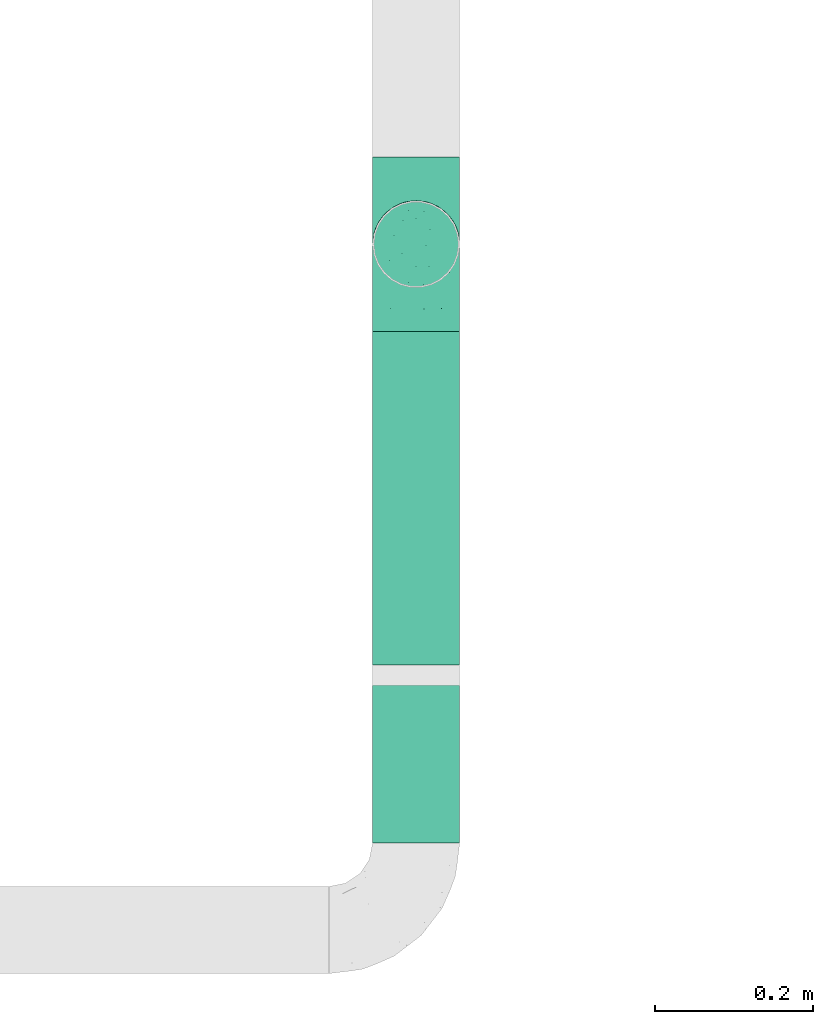
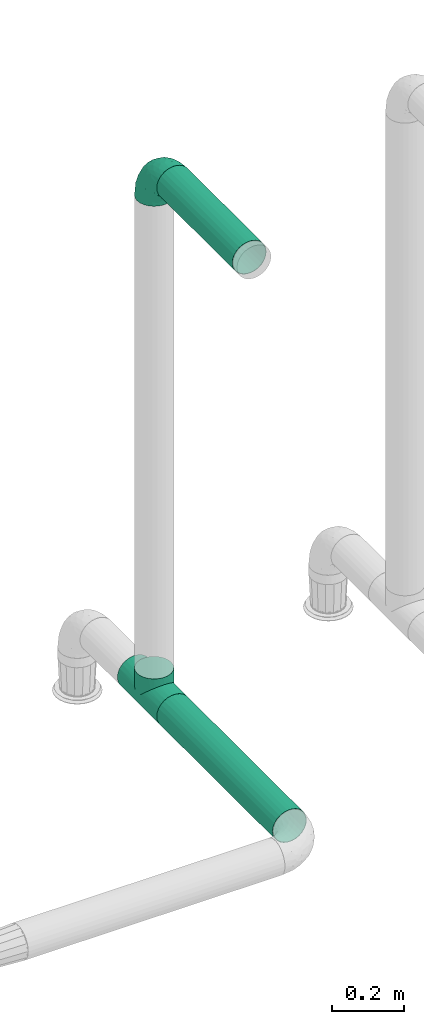
# One storey, part 9 of 103: 2 flow fittings, 2 flow segments.
"""IFC2X3 building model written with IfcOpenShell, lengths in millimetres."""

from ifc_helpers import new_model, entity, si_unit, converted_unit, derived_unit, direction, frame, origin_with_axes, origin_2d_with_axis, place, context, subcontext, project, spatial, hollow_circle, extrude, open_shell, surface_model, source, transform, mapped, material, layer, layer_set, layer_usage, type_object, element, save


model = new_model("IFC2X3")

# Units and contexts
model_context = context("Model", 3, precision=1e-05, world=origin_with_axes(), true_north=direction((0.0, 1.0)))
body_context = subcontext(model_context, "Body", "Model", "MODEL_VIEW")
ifc_project = project(units=[si_unit("AREAUNIT", "SQUARE_METRE"), si_unit("VOLUMEUNIT", "CUBIC_METRE", prefix="DECI"), si_unit("TIMEUNIT", "SECOND"), si_unit("THERMODYNAMICTEMPERATUREUNIT", "DEGREE_CELSIUS"), si_unit("PRESSUREUNIT", "PASCAL"), si_unit("MASSUNIT", "GRAM", prefix="KILO"), si_unit("LENGTHUNIT", "METRE", prefix="MILLI"), si_unit("POWERUNIT", "WATT"), si_unit("ELECTRICCURRENTUNIT", "AMPERE"), si_unit("ELECTRICVOLTAGEUNIT", "VOLT"), derived_unit("VOLUMETRICFLOWRATEUNIT", [(si_unit("VOLUMEUNIT", "CUBIC_METRE", prefix="DECI"), 1), (si_unit("TIMEUNIT", "SECOND"), -1)]), derived_unit("LINEARVELOCITYUNIT", [(si_unit("LENGTHUNIT", "METRE"), 1), (si_unit("TIMEUNIT", "SECOND"), -1)]), derived_unit("MASSDENSITYUNIT", [(si_unit("MASSUNIT", "GRAM", prefix="KILO"), 1), (si_unit("VOLUMEUNIT", "CUBIC_METRE"), -1)]), converted_unit("PLANEANGLEUNIT", "DEGREE", entity("IfcRatioMeasure", 0.01745), si_unit("PLANEANGLEUNIT", "RADIAN"), dimensions=[0, 0, 0, 0, 0, 0, 0])], contexts=[model_context])

# Site, building, storey
site_placement = place(None, origin_with_axes())
site = spatial("IfcSite", under=ifc_project, at=site_placement, CompositionType="ELEMENT")
building_placement = place(site_placement, origin_with_axes())
building = spatial("IfcBuilding", under=site, at=building_placement, Name="mc-building", CompositionType="ELEMENT")
storey_placement = place(building_placement, frame((0.0, 0.0, 5900.0), z_axis=(0.0, 0.0, 1.0), x_axis=(1.0, 0.0, 0.0)))
storey = spatial("IfcBuildingStorey", under=building, at=storey_placement, Name="3. Korrus", CompositionType="ELEMENT", Elevation=5900.0)

# Flow fitting
duct_fitting_type_1 = type_object("IfcDuctFittingType", PredefinedType="JUNCTION")
shared_shape_1 = source(origin_with_axes(), body_context, "Body", "SurfaceModel", [
    surface_model("IfcShellBasedSurfaceModel", [(0.0, -80.0, -55.0), (14.23505, -80.0, -53.12592), (-14.23505, -80.0, -53.12592), (-53.12592, -80.0, 14.23505), (-27.5, -80.0, -47.63139), (-47.63139, -80.0, -27.5), (-38.89087, -80.0, -38.89087), (55.0, -80.0, 0.0), (53.12592, -80.0, 14.23505), (38.89087, -80.0, -38.89087), (27.5, -80.0, -47.63139), (53.12592, -80.0, -14.23505), (47.63139, -80.0, -27.5), (-53.12592, -80.0, -14.23505), (-47.63139, -80.0, 27.5), (-38.89087, -80.0, 38.89087), (14.23505, -80.0, 53.12592), (-27.5, -80.0, 47.63139), (-14.23505, -80.0, 53.12592), (47.63139, -80.0, 27.5), (38.89087, -80.0, 38.89087), (27.5, -80.0, 47.63139), (0.0, -80.0, 55.0), (-55.0, -80.0, 0.0), (0.0, 0.0, 55.0), (-7.4066, -7.4066, 54.49901), (-14.74521, -14.74521, 52.98659), (-21.93978, -21.93978, 50.43457), (-28.89905, -28.89905, 46.79578), (-35.50357, -35.50357, 42.00591), (-41.58668, -41.58668, 35.99373), (-46.92319, -46.92319, 28.69171), (-51.19777, -51.19777, 20.0945), (-50.37866, -80.0, 20.86752), (-54.01174, -54.01174, 10.37938), (-55.0, -55.0, 0.0), (-54.06296, -80.0, 7.11752), (-54.01174, -54.01174, -10.37938), (-51.19777, -51.19777, -20.0945), (-54.06296, -80.0, -7.11752), (-46.92319, -46.92319, -28.69171), (-41.58668, -41.58668, -35.99373), (-50.37866, -80.0, -20.86752), (-35.50357, -35.50357, -42.00591), (-21.93978, -21.93978, -50.43457), (-14.74521, -14.74521, -52.98659), (-7.4066, -7.4066, -54.49901), (0.0, 0.0, -55.0), (-28.89905, -28.89905, -46.79578), (7.4066, -7.4066, -54.49901), (14.74521, -14.74521, -52.98659), (21.93978, -21.93978, -50.43457), (28.89905, -28.89905, -46.79578), (35.50357, -35.50357, -42.00591), (41.58668, -41.58668, -35.99373), (46.92319, -46.92319, -28.69171), (51.19777, -51.19777, -20.0945), (50.37866, -80.0, -20.86752), (54.01174, -54.01174, -10.37938), (55.0, -55.0, 0.0), (54.06296, -80.0, -7.11752), (54.01174, -54.01174, 10.37938), (51.19777, -51.19777, 20.0945), (54.06296, -80.0, 7.11752), (46.92319, -46.92319, 28.69171), (41.58668, -41.58668, 35.99373), (50.37866, -80.0, 20.86752), (35.50357, -35.50357, 42.00591), (21.93978, -21.93978, 50.43457), (14.74521, -14.74521, 52.98659), (7.4066, -7.4066, 54.49901), (28.89905, -28.89905, 46.79578), (-110.0, 0.0, -55.0), (-110.0, -14.23505, -53.12592), (-110.0, 14.23505, -53.12592), (-110.0, 53.12592, 14.23505), (-110.0, 27.5, -47.63139), (-110.0, 47.63139, -27.5), (-110.0, 38.89087, -38.89087), (-110.0, -55.0, 0.0), (-110.0, -53.12592, 14.23505), (-110.0, -38.89087, -38.89087), (-110.0, -27.5, -47.63139), (-110.0, -53.12592, -14.23505), (-110.0, -47.63139, -27.5), (-110.0, 53.12592, -14.23505), (-110.0, 47.63139, 27.5), (-110.0, 38.89087, 38.89087), (-110.0, -14.23505, 53.12592), (-110.0, 27.5, 47.63139), (-110.0, 14.23505, 53.12592), (-110.0, -47.63139, 27.5), (-110.0, -38.89087, 38.89087), (-110.0, -27.5, 47.63139), (-110.0, 0.0, 55.0), (-110.0, 55.0, 0.0), (110.0, 55.0, 0.0), (110.0, 0.0, -55.0), (110.0, 14.23505, -53.12592), (110.0, 27.5, -47.63139), (110.0, 38.89087, -38.89087), (110.0, 47.63139, -27.5), (110.0, -38.89087, -38.89087), (110.0, -53.12592, 14.23505), (110.0, -27.5, -47.63139), (110.0, -14.23505, -53.12592), (110.0, -47.63139, -27.5), (110.0, -53.12592, -14.23505), (110.0, -55.0, 0.0), (110.0, 53.12592, -14.23505), (110.0, 53.12592, 14.23505), (110.0, 47.63139, 27.5), (110.0, 38.89087, 38.89087), (110.0, 0.0, 55.0), (110.0, 27.5, 47.63139), (110.0, 14.23505, 53.12592), (110.0, -47.63139, 27.5), (110.0, -38.89087, 38.89087), (110.0, -27.5, 47.63139), (110.0, -14.23505, 53.12592)], [open_shell([[[0, 1, 2]], [[2, 3, 4]], [[5, 6, 3]], [[6, 4, 3]], [[2, 7, 8]], [[9, 7, 10]], [[1, 10, 7]], [[11, 7, 12]], [[9, 12, 7]], [[7, 2, 1]], [[5, 3, 13]], [[2, 14, 3]], [[2, 15, 14]], [[2, 16, 17]], [[17, 15, 2]], [[16, 18, 17]], [[2, 8, 19]], [[2, 19, 20]], [[2, 20, 21]], [[16, 2, 21]], [[16, 22, 18]], [[23, 13, 3]], [[24, 25, 22]], [[26, 27, 18]], [[25, 26, 18]], [[22, 25, 18]], [[17, 28, 29]], [[17, 18, 27]], [[17, 29, 15]], [[28, 17, 27]], [[30, 31, 14]], [[32, 3, 33]], [[32, 34, 3]], [[35, 36, 34]], [[31, 32, 14]], [[15, 30, 14]], [[34, 36, 3]], [[33, 14, 32]], [[36, 35, 23]], [[30, 15, 29]], [[37, 38, 13]], [[37, 13, 39]], [[40, 41, 5]], [[38, 5, 42]], [[38, 40, 5]], [[37, 39, 35]], [[35, 39, 23]], [[13, 38, 42]], [[41, 6, 5]], [[41, 43, 6]], [[44, 45, 2]], [[46, 47, 0]], [[45, 46, 2]], [[43, 48, 4]], [[44, 4, 48]], [[44, 2, 4]], [[46, 0, 2]], [[43, 4, 6]], [[47, 49, 0]], [[50, 51, 1]], [[49, 50, 1]], [[0, 49, 1]], [[10, 52, 53]], [[10, 1, 51]], [[10, 53, 9]], [[52, 10, 51]], [[54, 55, 12]], [[56, 11, 57]], [[56, 58, 11]], [[59, 60, 58]], [[55, 56, 12]], [[9, 54, 12]], [[58, 60, 11]], [[57, 12, 56]], [[60, 59, 7]], [[54, 9, 53]], [[61, 62, 8]], [[61, 8, 63]], [[64, 65, 19]], [[62, 19, 66]], [[62, 64, 19]], [[61, 63, 59]], [[7, 59, 63]], [[62, 66, 8]], [[65, 20, 19]], [[65, 67, 20]], [[68, 69, 16]], [[70, 24, 22]], [[69, 70, 16]], [[67, 71, 21]], [[68, 21, 71]], [[68, 16, 21]], [[70, 22, 16]], [[67, 21, 20]], [[72, 73, 74]], [[74, 75, 76]], [[77, 78, 75]], [[76, 75, 78]], [[74, 79, 80]], [[81, 79, 82]], [[73, 82, 79]], [[83, 79, 84]], [[81, 84, 79]], [[79, 74, 73]], [[77, 75, 85]], [[74, 86, 75]], [[74, 87, 86]], [[74, 88, 89]], [[89, 87, 74]], [[88, 90, 89]], [[74, 91, 92]], [[91, 74, 80]], [[92, 93, 74]], [[74, 93, 88]], [[88, 94, 90]], [[95, 85, 75]], [[96, 97, 98]], [[99, 96, 98]], [[96, 100, 101]], [[100, 96, 99]], [[102, 97, 103]], [[97, 102, 104]], [[104, 105, 97]], [[102, 103, 106]], [[106, 103, 107]], [[108, 107, 103]], [[109, 96, 101]], [[110, 111, 97]], [[97, 111, 112]], [[113, 97, 114]], [[97, 112, 114]], [[113, 114, 115]], [[116, 103, 97]], [[117, 116, 97]], [[118, 117, 97]], [[119, 118, 97]], [[119, 97, 113]], [[96, 110, 97]], [[24, 113, 115]], [[89, 115, 114]], [[94, 24, 90]], [[90, 24, 115]], [[115, 89, 90]], [[114, 87, 89]], [[86, 112, 111]], [[75, 111, 110]], [[95, 110, 96]], [[87, 112, 86]], [[86, 111, 75]], [[110, 95, 75]], [[112, 87, 114]], [[85, 96, 109]], [[77, 109, 101]], [[95, 96, 85]], [[85, 109, 77]], [[101, 78, 77]], [[101, 100, 78]], [[76, 100, 99]], [[74, 99, 98]], [[47, 98, 97]], [[76, 99, 74]], [[47, 72, 74]], [[98, 47, 74]], [[100, 76, 78]], [[47, 46, 72]], [[45, 44, 73]], [[46, 45, 73]], [[72, 46, 73]], [[82, 48, 43]], [[82, 73, 44]], [[82, 43, 81]], [[48, 82, 44]], [[41, 40, 84]], [[38, 37, 83]], [[40, 38, 84]], [[81, 41, 84]], [[37, 79, 83]], [[83, 84, 38]], [[79, 37, 35]], [[41, 81, 43]], [[49, 97, 105]], [[105, 104, 51]], [[53, 104, 102]], [[53, 52, 104]], [[49, 47, 97]], [[51, 50, 105]], [[52, 51, 104]], [[49, 105, 50]], [[54, 102, 106]], [[56, 106, 107]], [[58, 107, 108]], [[55, 54, 106]], [[58, 56, 107]], [[59, 58, 108]], [[55, 106, 56]], [[102, 54, 53]], [[34, 32, 80]], [[31, 30, 91]], [[32, 31, 91]], [[35, 34, 79]], [[80, 79, 34]], [[32, 91, 80]], [[30, 92, 91]], [[30, 29, 92]], [[27, 26, 88]], [[25, 24, 94]], [[26, 25, 88]], [[29, 28, 93]], [[27, 93, 28]], [[27, 88, 93]], [[25, 94, 88]], [[29, 93, 92]], [[61, 108, 103]], [[62, 103, 116]], [[65, 116, 117]], [[61, 59, 108]], [[64, 62, 116]], [[65, 64, 116]], [[61, 103, 62]], [[117, 67, 65]], [[71, 67, 118]], [[118, 67, 117]], [[68, 118, 119]], [[70, 119, 113]], [[68, 71, 118]], [[70, 69, 119]], [[24, 70, 113]], [[68, 119, 69]]])]),
])
flow_fitting_1_placement = place(storey_placement, frame((8385.80789, 4302.28735, 2345.0), z_axis=(-1.0, 0.0, 0.0), x_axis=(0.0, 1.0, 0.0)))
element("IfcFlowFitting", 1, at=flow_fitting_1_placement, inside=storey, type_object=duct_fitting_type_1, context=body_context, shape_type="MappedRepresentation", body=[
    mapped(shared_shape_1, transform((0.0, 0.0, 0.0), scale=1.0)),
])

# Flow segment
ifc_material = material(Name="FZ1")
ifc_layer = layer(ifc_material, 0.0)
ifc_layer_set = layer_set([ifc_layer], Name="FZ1")
ifc_layer_usage = layer_usage(ifc_layer_set, "AXIS1", "POSITIVE", 0.0)
duct_segment_type = type_object("IfcDuctSegmentType", Name="Safe", PredefinedType="RIGIDSEGMENT")
shared_shape_2 = source(origin_with_axes(), body_context, "Body", "SweptSolid", [
    extrude(hollow_circle(Radius=55.0, WallThickness=2.0, at=origin_2d_with_axis()), frame((0.0, 0.0, 0.0), z_axis=(1.0, 0.0, 0.0), x_axis=(0.0, 1.0, 0.0)), (0.0, 0.0, 1.0), 645.5),
])
flow_segment_1_placement = place(storey_placement, frame((8385.80789, 3546.80698, 2345.0), z_axis=(0.0, 0.0, 1.0), x_axis=(0.0, 1.0, 0.0)))
element("IfcFlowSegment", 2, at=flow_segment_1_placement, inside=storey, type_object=duct_segment_type, material=ifc_layer_usage, Name="Safe", context=body_context, shape_type="MappedRepresentation", body=[
    mapped(shared_shape_2, transform((0.0, 0.0, 0.0), scale=1.0)),
])

# Flow fitting
duct_fitting_type_2 = type_object("IfcDuctFittingType", Name="BU", PredefinedType="BEND")
shared_shape_3 = source(origin_with_axes(), body_context, "Body", "SurfaceModel", [
    surface_model("IfcShellBasedSurfaceModel", [(-110.0, 0.0, -55.0), (-110.0, -14.23505, -53.12592), (-110.0, 14.23505, -53.12592), (-110.0, 53.12592, 14.23505), (-110.0, 27.5, -47.63139), (-110.0, 38.89087, -38.89087), (-110.0, -55.0, 0.0), (-110.0, -53.12592, 14.23505), (-110.0, -38.89087, -38.89087), (-110.0, -27.5, -47.63139), (-110.0, -53.12592, -14.23505), (-110.0, -47.63139, -27.5), (-110.0, -14.23505, 53.12592), (-110.0, 14.23505, 53.12592), (-110.0, 27.5, 47.63139), (-110.0, -47.63139, 27.5), (-110.0, -38.89087, 38.89087), (-110.0, -27.5, 47.63139), (-110.0, 0.0, 55.0), (-110.0, 55.0, 0.0), (-110.0, 53.12592, -14.23505), (-110.0, 47.63139, -27.5), (-110.0, 47.63139, 27.5), (-110.0, 38.89087, 38.89087), (-14.23505, 110.0, -53.12592), (-55.0, 110.0, 0.0), (0.0, 110.0, -55.0), (-27.5, 110.0, -47.63139), (-38.89087, 110.0, -38.89087), (-47.63139, 110.0, -27.5), (38.89087, 110.0, -38.89087), (53.12592, 110.0, 14.23505), (27.5, 110.0, -47.63139), (14.23505, 110.0, -53.12592), (47.63139, 110.0, -27.5), (53.12592, 110.0, -14.23505), (55.0, 110.0, 0.0), (-53.12592, 110.0, -14.23505), (-53.12592, 110.0, 14.23505), (-47.63139, 110.0, 27.5), (-38.89087, 110.0, 38.89087), (-27.5, 110.0, 47.63139), (0.0, 110.0, 55.0), (-14.23505, 110.0, 53.12592), (38.89087, 110.0, 38.89087), (47.63139, 110.0, 27.5), (27.5, 110.0, 47.63139), (14.23505, 110.0, 53.12592), (-64.21732, 48.68956, 43.63444), (-76.6405, 38.18013, 45.55988), (-60.44912, 32.56953, 51.94617), (-76.00813, 5.38378, 55.0), (-90.15553, 11.94394, 54.09138), (-78.5998, 26.77405, 50.81338), (-70.18771, 18.55163, 54.03432), (-75.55424, 54.2118, 32.41257), (-93.27622, 45.77614, 33.48188), (-96.12334, 22.13664, 50.81337), (-21.00813, 45.34362, 55.0), (-18.36258, 70.48427, 54.04484), (-32.04182, 59.64019, 52.24446), (-63.88653, 74.77858, 17.99134), (-74.66383, 63.08407, 19.92123), (-63.60674, 66.07878, 29.97482), (-99.597, 52.72185, 18.52927), (-93.11138, 56.59448, 10.50359), (-98.21577, 57.34403, 0.0), (-53.42855, 92.60092, 21.04759), (-88.54852, 54.8376, 21.04759), (-11.86161, 90.23965, 54.10313), (-5.38378, 76.00813, 55.0), (-57.34403, 98.21577, 0.0), (-56.64619, 93.12774, 10.22088), (-45.34362, 21.00813, 55.0), (-44.60838, 44.60838, 52.13415), (-92.68484, 35.46673, 43.63443), (-22.25266, 95.40765, 50.81337), (-35.97783, 90.61597, 43.63443), (-43.70931, 69.58671, 44.47149), (-27.23711, 77.39884, 50.81337), (-57.2828, 79.3123, 24.9774), (-58.67786, 84.31125, 16.04456), (-82.93277, 60.36161, 12.91784), (-49.88337, 54.51816, 47.224), (-74.57753, 66.83759, 9.55742), (-45.35812, 94.97281, 33.48188), (-59.18663, 88.95241, 0.0), (-51.517, 78.6292, 33.48188), (-65.14788, 80.03077, 0.0), (-56.45322, 62.06476, 39.63545), (-88.95241, 59.18663, 0.0), (-71.10913, 71.10913, 0.0), (-80.03077, 65.14788, 0.0), (-94.9309, 45.36788, -33.48188), (-93.11358, 56.60141, -10.46614), (-99.64997, 52.79499, -18.30015), (-90.20425, 36.08686, -43.63443), (-79.99933, 46.56772, -37.92748), (-76.00813, 5.38378, -55.0), (-72.75364, 19.68651, -53.60527), (-45.34362, 21.00813, -55.0), (-21.91957, 65.12078, -53.85897), (-5.38378, 76.00813, -55.0), (-21.00813, 45.34362, -55.0), (-35.41876, 92.89265, -43.63443), (-91.10309, 11.02766, -54.21832), (-45.77614, 93.27622, -33.48188), (-90.50474, 23.21022, -50.81337), (-70.92854, 33.31794, -49.51754), (-78.52933, 63.35627, -11.73997), (-24.91508, 84.05606, -50.81337), (-88.78941, 54.74452, -21.04759), (-69.59921, 57.34866, -33.48187), (-73.36422, 62.46673, -22.94182), (-63.49062, 67.59111, -28.46929), (-56.59448, 93.11138, -10.50359), (-54.8376, 88.54852, -21.04759), (-54.10679, 75.85581, -32.31867), (-57.75956, 31.09612, -52.80882), (-52.72185, 99.597, -18.52927), (-12.62913, 89.46304, -53.99097), (-34.46825, 66.46123, -50.04329), (-43.9837, 43.9837, -52.42279), (-65.78527, 72.58348, -17.68796), (-70.34468, 43.65295, -44.21951), (-57.47001, 51.99467, -44.91465), (-60.72547, 82.29174, -12.88567), (-42.34915, 74.24548, -43.63444), (-57.25194, 63.5016, -38.08211), (-80.95344, 53.56991, -29.32027), (-52.32891, 4.55257, -54.0482), (32.52942, 47.13398, -30.48571), (14.88266, 20.92917, -33.7947), (14.95561, 36.05775, -42.26543), (30.24048, 70.09027, -41.7461), (19.3559, 65.35825, -48.00507), (-70.35075, -46.44478, -19.5952), (-47.13398, -32.52942, -30.48571), (-28.49299, -30.5778, -16.4009), (-4.55257, 52.32891, -54.0482), (-22.4954, 22.4954, -53.25347), (-75.47368, -11.22546, -52.60718), (-81.32209, -51.5606, -9.98467), (-80.81763, -41.84862, -32.14655), (-70.09027, -30.24048, -41.7461), (-36.05774, -14.95561, -42.26543), (-9.15831, -10.852, -27.8997), (-65.35825, -19.3559, -48.00507), (11.22546, 75.47368, -52.60718), (3.94376, 43.9333, -50.53315), (-13.39742, 13.39743, -48.13058), (-43.9333, -3.94376, -50.53315), (49.37776, 67.29486, 0.0), (41.8609, 47.82256, -9.92641), (50.20582, 74.51695, -9.9731), (18.93131, 11.7156, -17.56239), (-27.5, -32.89419, 0.0), (-1.23348, -12.25375, -12.18106), (41.84862, 80.81763, -32.14655), (35.70604, 41.31408, -20.38235), (46.44478, 70.35075, -19.5952), (32.89419, 27.5, 0.0), (6.67262, -6.67262, 0.0), (-67.29486, -49.37776, 0.0), (-50.36265, -42.95545, -9.51562), (-5.47251, 5.47251, -39.92906), (-70.35075, -46.44478, 19.5952), (-74.51695, -50.20582, 9.9731), (-41.31407, -35.70604, 20.38235), (-47.13398, -32.52942, 30.48571), (-80.81763, -41.84862, 32.14655), (-4.55257, 52.32891, 54.0482), (11.22546, 75.47368, 52.60718), (-43.9333, -3.94376, 50.53315), (-65.35825, -19.3559, 48.00507), (-36.05774, -14.95561, 42.26543), (-70.09027, -30.24048, 41.7461), (-11.7156, -18.93131, 17.56239), (30.5778, 28.49299, 16.4009), (12.25375, 1.23348, 12.18106), (51.5606, 81.32209, 9.98467), (42.95545, 50.36265, 9.51562), (-75.47368, -11.22546, 52.60718), (-52.32891, 4.55257, 54.0482), (3.94376, 43.9333, 50.53315), (-22.4954, 22.4954, 53.25347), (-13.39742, 13.39743, 48.13058), (10.852, 9.15831, 27.8997), (-20.92916, -14.88266, 33.79469), (-47.82256, -41.8609, 9.92641), (32.52942, 47.13398, 30.48571), (46.44478, 70.35075, 19.5952), (41.84862, 80.81763, 32.14655), (30.24048, 70.09027, 41.7461), (19.3559, 65.35825, 48.00507), (14.95561, 36.05775, 42.26543), (-5.47251, 5.47251, 39.92906)], [open_shell([[[0, 1, 2]], [[2, 3, 4]], [[4, 3, 5]], [[2, 6, 7]], [[8, 6, 9]], [[1, 9, 6]], [[10, 6, 11]], [[8, 11, 6]], [[6, 2, 1]], [[12, 13, 14]], [[15, 2, 7]], [[16, 17, 2]], [[2, 17, 12]], [[12, 18, 13]], [[19, 20, 3]], [[5, 3, 21]], [[20, 21, 3]], [[22, 3, 2]], [[23, 22, 2]], [[12, 14, 2]], [[2, 14, 23]], [[15, 16, 2]], [[24, 25, 26]], [[27, 25, 24]], [[25, 28, 29]], [[28, 25, 27]], [[30, 26, 31]], [[26, 30, 32]], [[32, 33, 26]], [[34, 31, 35]], [[31, 34, 30]], [[35, 31, 36]], [[29, 37, 25]], [[38, 39, 26]], [[39, 40, 26]], [[41, 42, 40]], [[42, 26, 40]], [[42, 41, 43]], [[26, 44, 45]], [[31, 26, 45]], [[26, 46, 44]], [[47, 46, 26]], [[42, 47, 26]], [[25, 38, 26]], [[48, 49, 50]], [[18, 51, 52]], [[53, 54, 50]], [[55, 56, 49]], [[56, 22, 23]], [[13, 57, 14]], [[58, 59, 60]], [[61, 62, 63]], [[3, 64, 65]], [[53, 52, 54]], [[3, 65, 66]], [[67, 39, 38]], [[56, 68, 64]], [[65, 64, 68]], [[69, 59, 70]], [[38, 71, 72]], [[73, 58, 74]], [[75, 49, 56]], [[76, 69, 43]], [[53, 57, 52]], [[77, 78, 79]], [[41, 76, 43]], [[43, 69, 42]], [[55, 68, 56]], [[23, 14, 75]], [[76, 77, 79]], [[80, 67, 81]], [[62, 82, 68]], [[60, 78, 83]], [[62, 84, 82]], [[85, 77, 40]], [[81, 67, 72]], [[86, 72, 71]], [[87, 85, 67]], [[61, 81, 88]], [[77, 41, 40]], [[78, 77, 87]], [[23, 75, 56]], [[83, 89, 48]], [[85, 40, 39]], [[62, 68, 55]], [[89, 87, 63]], [[83, 48, 50]], [[57, 75, 14]], [[49, 75, 53]], [[67, 85, 39]], [[87, 77, 85]], [[63, 62, 55]], [[89, 55, 48]], [[80, 63, 87]], [[66, 65, 90]], [[66, 19, 3]], [[84, 91, 92]], [[92, 90, 82]], [[65, 82, 90]], [[61, 84, 62]], [[92, 82, 84]], [[68, 82, 65]], [[3, 22, 64]], [[56, 64, 22]], [[38, 25, 71]], [[81, 72, 86]], [[38, 72, 67]], [[91, 61, 88]], [[80, 81, 61]], [[63, 80, 61]], [[67, 80, 87]], [[77, 76, 41]], [[79, 59, 69]], [[79, 69, 76]], [[42, 69, 70]], [[60, 59, 79]], [[58, 70, 59]], [[78, 60, 79]], [[58, 60, 74]], [[52, 57, 13]], [[75, 57, 53]], [[18, 52, 13]], [[52, 51, 54]], [[51, 73, 54]], [[50, 73, 74]], [[73, 50, 54]], [[50, 74, 83]], [[60, 83, 74]], [[89, 83, 78]], [[87, 89, 78]], [[55, 89, 63]], [[50, 49, 53]], [[55, 49, 48]], [[81, 86, 88]], [[91, 84, 61]], [[5, 21, 93]], [[90, 94, 66]], [[20, 94, 95]], [[96, 93, 97]], [[98, 99, 100]], [[96, 4, 5]], [[101, 102, 103]], [[28, 27, 104]], [[2, 105, 0]], [[104, 106, 28]], [[99, 105, 107]], [[108, 107, 96]], [[90, 109, 94]], [[107, 2, 4]], [[20, 66, 94]], [[27, 24, 110]], [[109, 111, 94]], [[112, 113, 114]], [[37, 115, 71]], [[116, 106, 117]], [[99, 118, 100]], [[116, 115, 119]], [[37, 119, 115]], [[24, 120, 110]], [[121, 110, 101]], [[119, 106, 116]], [[101, 110, 120]], [[122, 103, 100]], [[117, 123, 116]], [[124, 125, 108]], [[115, 116, 126]], [[106, 29, 28]], [[26, 102, 120]], [[127, 104, 110]], [[97, 124, 96]], [[125, 122, 118]], [[128, 127, 125]], [[96, 5, 93]], [[115, 126, 86]], [[117, 106, 127]], [[111, 113, 129]], [[95, 93, 21]], [[97, 129, 112]], [[110, 104, 27]], [[106, 104, 127]], [[96, 107, 4]], [[99, 107, 108]], [[99, 108, 118]], [[105, 99, 98]], [[112, 114, 128]], [[121, 125, 127]], [[20, 19, 66]], [[109, 90, 92]], [[94, 111, 95]], [[91, 123, 109]], [[129, 113, 112]], [[93, 95, 111]], [[21, 20, 95]], [[71, 115, 86]], [[71, 25, 37]], [[123, 91, 88]], [[126, 116, 123]], [[123, 88, 126]], [[86, 126, 88]], [[37, 29, 119]], [[106, 119, 29]], [[129, 93, 111]], [[124, 112, 125]], [[0, 105, 98]], [[107, 105, 2]], [[125, 118, 108]], [[100, 118, 122]], [[93, 129, 97]], [[113, 111, 109]], [[109, 123, 113]], [[114, 123, 117]], [[123, 114, 113]], [[128, 114, 117]], [[127, 128, 117]], [[112, 128, 125]], [[103, 122, 101]], [[110, 121, 127]], [[101, 122, 121]], [[125, 121, 122]], [[26, 120, 24]], [[101, 120, 102]], [[96, 124, 108]], [[92, 91, 109]], [[112, 124, 97]], [[100, 130, 98]], [[131, 132, 133]], [[32, 134, 135]], [[136, 137, 138]], [[139, 140, 103]], [[98, 141, 0]], [[142, 10, 136]], [[143, 144, 137]], [[6, 10, 142]], [[137, 145, 146]], [[144, 147, 145]], [[143, 136, 11]], [[11, 136, 10]], [[8, 143, 11]], [[148, 149, 139]], [[8, 9, 144]], [[9, 1, 147]], [[130, 141, 98]], [[103, 140, 100]], [[148, 135, 149]], [[150, 151, 140]], [[152, 153, 154]], [[130, 140, 151]], [[148, 26, 33]], [[147, 1, 141]], [[155, 146, 132]], [[156, 138, 157]], [[134, 30, 158]], [[150, 140, 149]], [[158, 30, 34]], [[30, 134, 32]], [[153, 159, 160]], [[131, 160, 159]], [[144, 145, 137]], [[36, 152, 154]], [[146, 138, 137]], [[155, 161, 162]], [[158, 160, 131]], [[133, 149, 135]], [[156, 163, 164]], [[163, 142, 164]], [[139, 103, 102]], [[153, 152, 161]], [[34, 35, 160]], [[162, 157, 155]], [[132, 165, 133]], [[157, 146, 155]], [[140, 130, 100]], [[141, 130, 151]], [[141, 151, 147]], [[141, 1, 0]], [[102, 26, 148]], [[140, 139, 149]], [[102, 148, 139]], [[135, 33, 32]], [[151, 150, 145]], [[9, 147, 144]], [[151, 145, 147]], [[145, 165, 146]], [[135, 148, 33]], [[133, 135, 134]], [[131, 133, 134]], [[133, 165, 150]], [[133, 150, 149]], [[145, 150, 165]], [[132, 131, 159]], [[146, 165, 132]], [[160, 158, 34]], [[134, 158, 131]], [[144, 143, 8]], [[136, 143, 137]], [[155, 153, 161]], [[154, 153, 160]], [[153, 155, 159]], [[132, 159, 155]], [[160, 35, 154]], [[36, 154, 35]], [[164, 136, 138]], [[6, 142, 163]], [[136, 164, 142]], [[156, 164, 138]], [[156, 157, 162]], [[146, 157, 138]], [[15, 7, 166]], [[6, 163, 167]], [[168, 169, 166]], [[166, 169, 170]], [[171, 172, 70]], [[173, 174, 175]], [[17, 176, 174]], [[177, 156, 162]], [[176, 16, 170]], [[170, 16, 15]], [[161, 178, 179]], [[152, 180, 181]], [[182, 173, 183]], [[18, 12, 182]], [[184, 185, 186]], [[183, 185, 73]], [[183, 73, 51]], [[177, 187, 188]], [[189, 168, 166]], [[187, 178, 190]], [[16, 176, 17]], [[161, 152, 181]], [[45, 191, 31]], [[45, 44, 192]], [[192, 191, 45]], [[180, 36, 31]], [[193, 194, 195]], [[46, 47, 194]], [[193, 195, 190]], [[193, 44, 46]], [[172, 42, 70]], [[185, 58, 73]], [[189, 163, 156]], [[163, 189, 167]], [[70, 58, 171]], [[184, 171, 185]], [[169, 188, 175]], [[180, 31, 191]], [[192, 193, 190]], [[191, 190, 178]], [[182, 174, 173]], [[194, 47, 172]], [[190, 195, 187]], [[186, 185, 173]], [[162, 179, 177]], [[188, 196, 175]], [[179, 187, 177]], [[185, 171, 58]], [[172, 171, 184]], [[172, 184, 194]], [[172, 47, 42]], [[51, 18, 182]], [[185, 183, 173]], [[51, 182, 183]], [[174, 12, 17]], [[184, 186, 195]], [[46, 194, 193]], [[184, 195, 194]], [[195, 196, 187]], [[174, 182, 12]], [[175, 174, 176]], [[169, 175, 176]], [[175, 196, 186]], [[175, 186, 173]], [[195, 186, 196]], [[188, 169, 168]], [[187, 196, 188]], [[166, 170, 15]], [[176, 170, 169]], [[193, 192, 44]], [[191, 192, 190]], [[177, 189, 156]], [[167, 189, 166]], [[189, 177, 168]], [[188, 168, 177]], [[166, 7, 167]], [[6, 167, 7]], [[181, 191, 178]], [[36, 180, 152]], [[191, 181, 180]], [[161, 181, 178]], [[161, 179, 162]], [[187, 179, 178]]])]),
])
flow_fitting_2_placement = place(storey_placement, frame((8385.80789, 4302.28735, 4144.0), z_axis=(1.0, 0.0, 0.0), x_axis=(0.0, 0.0, 1.0)))
element("IfcFlowFitting", 3, at=flow_fitting_2_placement, inside=storey, type_object=duct_fitting_type_2, Name="BU", context=body_context, shape_type="MappedRepresentation", body=[
    mapped(shared_shape_3, transform((0.0, 0.0, 0.0), scale=1.0)),
])

# Flow segment
shared_shape_4 = source(origin_with_axes(), body_context, "Body", "SweptSolid", [
    extrude(hollow_circle(Radius=55.0, WallThickness=2.0, at=origin_2d_with_axis()), frame((0.0, 0.0, 0.0), z_axis=(1.0, 0.0, 0.0), x_axis=(0.0, 1.0, 0.0)), (0.0, 0.0, 1.0), 421.1),
])
flow_segment_2_placement = place(storey_placement, frame((8385.80789, 3771.20513, 4144.0), z_axis=(0.0, 0.0, 1.0), x_axis=(0.0, 1.0, 0.0)))
element("IfcFlowSegment", 4, at=flow_segment_2_placement, inside=storey, type_object=duct_segment_type, material=ifc_layer_usage, Name="Safe", context=body_context, shape_type="MappedRepresentation", body=[
    mapped(shared_shape_4, transform((0.0, 0.0, 0.0), scale=1.0)),
])

save(model, "model.ifc")
